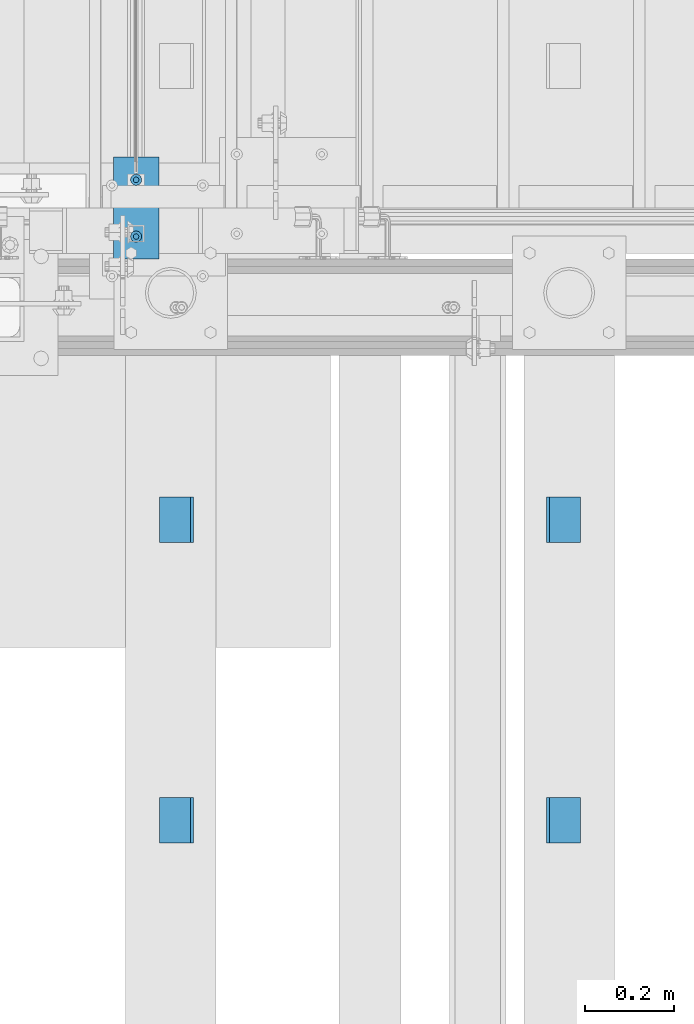
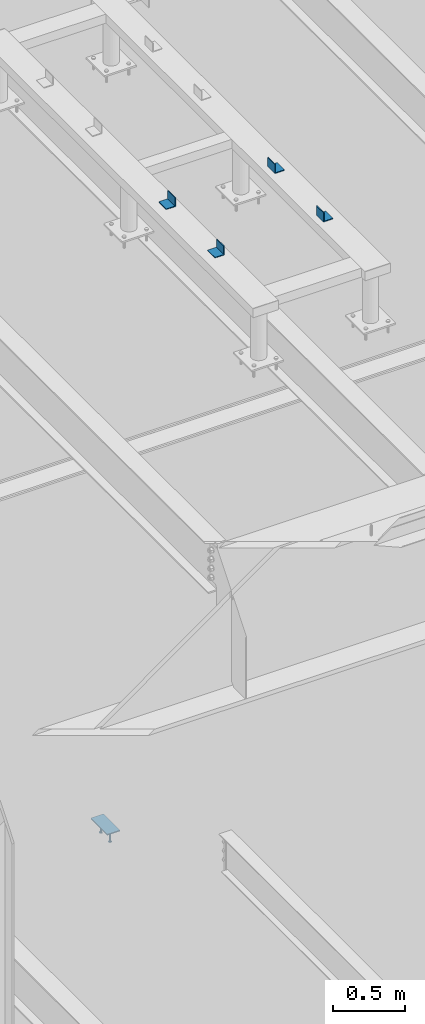
# One storey, part 901 of 1179: 7 beams, 2 elements without a shape of their own.
"""IFC2X3 building model written with IfcOpenShell, lengths in millimetres."""

from ifc_helpers import new_model, si_unit, frame, origin_with_axes, place, context, subcontext, project, spatial, faceted_brep, material, type_object, element, aggregate, save


model = new_model("IFC2X3")

# Units and contexts
model_context = context("Model", 3, precision=1e-05, world=origin_with_axes())
body_context = subcontext(model_context, "Body", "Model", "MODEL_VIEW")
ifc_project = project(units=[si_unit("LENGTHUNIT", "METRE", prefix="MILLI"), si_unit("AREAUNIT", "SQUARE_METRE"), si_unit("VOLUMEUNIT", "CUBIC_METRE"), si_unit("MASSUNIT", "GRAM", prefix="KILO"), si_unit("TIMEUNIT", "SECOND"), si_unit("PLANEANGLEUNIT", "RADIAN"), si_unit("SOLIDANGLEUNIT", "STERADIAN"), si_unit("THERMODYNAMICTEMPERATUREUNIT", "DEGREE_CELSIUS"), si_unit("LUMINOUSINTENSITYUNIT", "LUMEN")], contexts=[model_context])

# Site, building, storey
site_placement = place(None, origin_with_axes())
site = spatial("IfcSite", under=ifc_project, at=site_placement, CompositionType="ELEMENT")
building_placement = place(site_placement, origin_with_axes())
building = spatial("IfcBuilding", under=site, at=building_placement, Name="Undefined", CompositionType="ELEMENT")
storey_placement = place(building_placement, origin_with_axes())
storey = spatial("IfcBuildingStorey", under=building, at=storey_placement, Name="Undefined", CompositionType="ELEMENT", Elevation=0.0)

# Assembly, beams
assembly_1_placement = place(storey_placement, origin_with_axes())
assembly_1 = element("IfcElementAssembly", 1, at=assembly_1_placement, inside=storey, Name="EMBED", AssemblyPlace="NOTDEFINED", PredefinedType="RIGID_FRAME")
ifc_material_1 = material(Name="STEEL/A108")
beam_type_1 = type_object("IfcBeamType", Name="STUD_1/2-DIA", PredefinedType="NOTDEFINED")
beam_1_placement = place(assembly_1_placement, frame((19605.6250006919, 38144.44999694, 8137.525), z_axis=(0.0, -1.0, 0.0), x_axis=(0.0, 0.0, -1.0)))
beam_1 = element("IfcBeam", 2, at=beam_1_placement, type_object=beam_type_1, material=ifc_material_1, Name="SHEAR STUD", ObjectType="STUD_1/2-DIA", context=body_context, shape_type="Brep", body=[
    faceted_brep([(0.0, -3.1800000667572, 5.5), (0.0, -5.5, 3.1800000667572), (94.4880000000003, -5.5, 3.1800000667572), (94.4880000000003, -3.1800000667572, 5.5), (0.0, -6.34999999999854, 0.0), (94.4880000000003, -6.34999990463257, 0.0), (0.0, -5.5, -3.1800000667572), (94.4880000000003, -5.5, -3.1800000667572), (0.0, -3.1800000667572, -5.5), (94.4880000000003, -3.1800000667572, -5.5), (0.0, 0.0, -6.34999999999991), (94.4880000000003, 0.0, -6.34999990463257), (0.0, 3.1800000667572, -5.5), (94.4880000000003, 3.1800000667572, -5.5), (0.0, 5.5, -3.1800000667572), (94.4880000000003, 5.5, -3.1800000667572), (0.0, 6.34999999999854, 0.0), (94.4880000000003, 6.34999990463257, 0.0), (0.0, 5.5, 3.1800000667572), (94.4880000000003, 5.5, 3.1800000667572), (0.0, 3.1800000667572, 5.5), (94.4880000000003, 3.1800000667572, 5.5), (0.0, 0.0, 6.34999999999991), (94.4880000000003, 0.0, 6.34999990463257), (96.5200000000004, -10.9899997711182, 6.34999990463257), (96.5200000000004, -6.34000015258789, 10.9899997711182), (96.5200000000004, -12.6999998092651, 0.0), (96.5200000000004, -10.9899997711182, -6.34999990463257), (96.5200000000004, -6.34000015258789, -10.9899997711182), (96.5200000000004, 0.0, -12.6899995803833), (96.5200000000004, 6.34000015258789, -10.9899997711182), (96.5200000000004, 10.9899997711182, -6.34999990463257), (96.5200000000004, 12.6999998092651, 0.0), (96.5200000000004, 10.9899997711182, 6.34999990463257), (96.5200000000004, 6.34000015258789, 10.9899997711182), (96.5200000000004, 0.0, 12.6899995803833), (101.6, -10.9899997711182, 6.34999990463257), (101.6, -6.34000015258789, 10.9899997711182), (101.6, -12.6999998092651, 0.0), (101.6, -10.9899997711182, -6.34999990463257), (101.6, -6.34000015258789, -10.9899997711182), (101.6, 0.0, -12.6899995803833), (101.6, 6.34000015258789, -10.9899997711182), (101.6, 10.9899997711182, -6.34999990463257), (101.6, 12.6999998092651, 0.0), (101.6, 10.9899997711182, 6.34999990463257), (101.6, 6.34000015258789, 10.9899997711182), (101.6, 0.0, 12.6899995803833)], [[[0, 1, 2, 3]], [[1, 4, 5, 2]], [[4, 6, 7, 5]], [[6, 8, 9, 7]], [[8, 10, 11, 9]], [[10, 12, 13, 11]], [[12, 14, 15, 13]], [[14, 16, 17, 15]], [[16, 18, 19, 17]], [[18, 20, 21, 19]], [[20, 22, 23, 21]], [[22, 0, 3, 23]], [[22, 20, 18, 16, 14, 12, 10, 8, 6, 4, 1, 0]], [[3, 2, 24, 25]], [[2, 5, 26, 24]], [[5, 7, 27, 26]], [[7, 9, 28, 27]], [[9, 11, 29, 28]], [[11, 13, 30, 29]], [[13, 15, 31, 30]], [[15, 17, 32, 31]], [[17, 19, 33, 32]], [[19, 21, 34, 33]], [[21, 23, 35, 34]], [[23, 3, 25, 35]], [[25, 24, 36, 37]], [[24, 26, 38, 36]], [[26, 27, 39, 38]], [[27, 28, 40, 39]], [[28, 29, 41, 40]], [[29, 30, 42, 41]], [[30, 31, 43, 42]], [[31, 32, 44, 43]], [[32, 33, 45, 44]], [[33, 34, 46, 45]], [[34, 35, 47, 46]], [[35, 25, 37, 47]], [[38, 39, 40, 41, 42, 43, 44, 45, 46, 47, 37, 36]]]),
])
beam_2_placement = place(assembly_1_placement, frame((19605.6250006919, 38271.44999694, 8137.525), z_axis=(0.0, -1.0, 0.0), x_axis=(0.0, 0.0, -1.0)))
beam_2 = element("IfcBeam", 3, at=beam_2_placement, type_object=beam_type_1, material=ifc_material_1, Name="SHEAR STUD", ObjectType="STUD_1/2-DIA", context=body_context, shape_type="Brep", body=[
    faceted_brep([(0.0, -3.1800000667572, 5.5), (0.0, -5.5, 3.1800000667572), (94.4880000000003, -5.5, 3.1800000667572), (94.4880000000003, -3.1800000667572, 5.5), (0.0, -6.34999999999854, 0.0), (94.4880000000003, -6.34999990463257, 0.0), (0.0, -5.5, -3.1800000667572), (94.4880000000003, -5.5, -3.1800000667572), (0.0, -3.1800000667572, -5.5), (94.4880000000003, -3.1800000667572, -5.5), (0.0, 0.0, -6.34999999999991), (94.4880000000003, 0.0, -6.34999990463257), (0.0, 3.1800000667572, -5.5), (94.4880000000003, 3.1800000667572, -5.5), (0.0, 5.5, -3.1800000667572), (94.4880000000003, 5.5, -3.1800000667572), (0.0, 6.34999999999854, 0.0), (94.4880000000003, 6.34999990463257, 0.0), (0.0, 5.5, 3.1800000667572), (94.4880000000003, 5.5, 3.1800000667572), (0.0, 3.1800000667572, 5.5), (94.4880000000003, 3.1800000667572, 5.5), (0.0, 0.0, 6.34999999999991), (94.4880000000003, 0.0, 6.34999990463257), (96.5200000000004, -10.9899997711182, 6.34999990463257), (96.5200000000004, -6.34000015258789, 10.9899997711182), (96.5200000000004, -12.6999998092651, 0.0), (96.5200000000004, -10.9899997711182, -6.34999990463257), (96.5200000000004, -6.34000015258789, -10.9899997711182), (96.5200000000004, 0.0, -12.6899995803833), (96.5200000000004, 6.34000015258789, -10.9899997711182), (96.5200000000004, 10.9899997711182, -6.34999990463257), (96.5200000000004, 12.6999998092651, 0.0), (96.5200000000004, 10.9899997711182, 6.34999990463257), (96.5200000000004, 6.34000015258789, 10.9899997711182), (96.5200000000004, 0.0, 12.6899995803833), (101.6, -10.9899997711182, 6.34999990463257), (101.6, -6.34000015258789, 10.9899997711182), (101.6, -12.6999998092651, 0.0), (101.6, -10.9899997711182, -6.34999990463257), (101.6, -6.34000015258789, -10.9899997711182), (101.6, 0.0, -12.6899995803833), (101.6, 6.34000015258789, -10.9899997711182), (101.6, 10.9899997711182, -6.34999990463257), (101.6, 12.6999998092651, 0.0), (101.6, 10.9899997711182, 6.34999990463257), (101.6, 6.34000015258789, 10.9899997711182), (101.6, 0.0, 12.6899995803833)], [[[0, 1, 2, 3]], [[1, 4, 5, 2]], [[4, 6, 7, 5]], [[6, 8, 9, 7]], [[8, 10, 11, 9]], [[10, 12, 13, 11]], [[12, 14, 15, 13]], [[14, 16, 17, 15]], [[16, 18, 19, 17]], [[18, 20, 21, 19]], [[20, 22, 23, 21]], [[22, 0, 3, 23]], [[22, 20, 18, 16, 14, 12, 10, 8, 6, 4, 1, 0]], [[3, 2, 24, 25]], [[2, 5, 26, 24]], [[5, 7, 27, 26]], [[7, 9, 28, 27]], [[9, 11, 29, 28]], [[11, 13, 30, 29]], [[13, 15, 31, 30]], [[15, 17, 32, 31]], [[17, 19, 33, 32]], [[19, 21, 34, 33]], [[21, 23, 35, 34]], [[23, 3, 25, 35]], [[25, 24, 36, 37]], [[24, 26, 38, 36]], [[26, 27, 39, 38]], [[27, 28, 40, 39]], [[28, 29, 41, 40]], [[29, 30, 42, 41]], [[30, 31, 43, 42]], [[31, 32, 44, 43]], [[32, 33, 45, 44]], [[33, 34, 46, 45]], [[34, 35, 47, 46]], [[35, 25, 37, 47]], [[38, 39, 40, 41, 42, 43, 44, 45, 46, 47, 37, 36]]]),
])
ifc_material_2 = material(Name="STEEL/A36")
beam_type_2 = type_object("IfcBeamType", PredefinedType="NOTDEFINED")
beam_3_placement = place(assembly_1_placement, frame((19605.6250006919, 38322.24999694, 8142.2875), z_axis=(1.0, 0.0, 0.0), x_axis=(0.0, -1.0, 0.0)))
beam_3 = element("IfcBeam", 4, at=beam_3_placement, type_object=beam_type_2, material=ifc_material_2, Name="EMBED", context=body_context, shape_type="Brep", body=[
    faceted_brep([(0.0, 4.76249999999982, -50.7999999999993), (0.0, 4.76249999999982, 50.7999999999993), (228.599999999999, 4.76249999999982, 50.7999999999993), (228.599999999999, 4.76249999999982, -50.7999999999993), (0.0, -4.76249999999982, 50.7999999999993), (228.599999999999, -4.76249999999982, 50.7999999999993), (0.0, -4.76249999999982, -50.7999999999993), (228.599999999999, -4.76249999999982, -50.7999999999993)], [[[0, 1, 2, 3]], [[1, 4, 5, 2]], [[4, 6, 7, 5]], [[6, 0, 3, 7]], [[5, 7, 3, 2]], [[6, 4, 1, 0]]]),
])
aggregate(assembly_1, [beam_1, beam_2, beam_3])

assembly_2_placement = place(storey_placement, origin_with_axes())
assembly_2 = element("IfcElementAssembly", 5, at=assembly_2_placement, inside=storey, Name="FRAME", AssemblyPlace="NOTDEFINED", PredefinedType="RIGID_FRAME")
beam_type_3 = type_object("IfcBeamType", Name="L3X3X1/4", PredefinedType="NOTDEFINED")
beam_4_placement = place(assembly_2_placement, frame((19696.1125, 37459.5225542222, 13798.55), z_axis=(-1.0, 0.0, 0.0), x_axis=(0.0, 1.0, 0.0)))
beam_4 = element("IfcBeam", 6, at=beam_4_placement, type_object=beam_type_3, material=ifc_material_2, Name="ANGLE", ObjectType="L3X3X1/4", context=body_context, shape_type="Brep", body=[
    faceted_brep([(0.0, 38.0999999999985, -38.0999999999999), (0.0, 38.0999999999985, 38.0999999999999), (101.600000000035, 38.0999999999985, 38.099999999994), (101.599999999962, 38.0999999999985, -38.1000000000058), (0.0, 31.75, 38.1000000000004), (101.600000000035, 31.75, 38.099999999994), (0.0, 31.75, -31.75), (101.599999999969, 31.75, -31.7500000000064), (0.0, -38.0999999999985, -31.75), (101.599999999969, -38.0999999999985, -31.7500000000064), (0.0, -38.0999999999985, -38.0999999999999), (101.599999999962, -38.0999999999985, -38.1000000000058)], [[[0, 1, 2, 3]], [[1, 4, 5, 2]], [[4, 6, 7, 5]], [[6, 8, 9, 7]], [[8, 10, 11, 9]], [[10, 0, 3, 11]], [[5, 7, 9, 11, 3, 2]], [[10, 8, 6, 4, 1, 0]]]),
])
beam_5_placement = place(assembly_2_placement, frame((20562.8875, 37459.5225542222, 13798.55), z_axis=(0.0, 0.0, 1.0), x_axis=(0.0, 1.0, 0.0)))
beam_5 = element("IfcBeam", 7, at=beam_5_placement, type_object=beam_type_3, material=ifc_material_2, Name="ANGLE", ObjectType="L3X3X1/4", context=body_context, shape_type="Brep", body=[
    faceted_brep([(0.0, 38.0999999999985, -38.0999999999999), (0.0, 38.0999999999985, 38.0999999999999), (101.600000000035, 38.0999999999985, 38.099999999994), (101.599999999962, 38.0999999999985, -38.1000000000058), (0.0, 31.75, 38.1000000000004), (101.600000000035, 31.75, 38.099999999994), (0.0, 31.75, -31.75), (101.599999999969, 31.75, -31.7500000000064), (0.0, -38.0999999999985, -31.75), (101.599999999969, -38.0999999999985, -31.7500000000064), (0.0, -38.0999999999985, -38.0999999999999), (101.599999999962, -38.0999999999985, -38.1000000000058)], [[[0, 1, 2, 3]], [[1, 4, 5, 2]], [[4, 6, 7, 5]], [[6, 8, 9, 7]], [[8, 10, 11, 9]], [[10, 0, 3, 11]], [[5, 7, 9, 11, 3, 2]], [[10, 8, 6, 4, 1, 0]]]),
])
beam_6_placement = place(assembly_2_placement, frame((20562.8875, 36786.4225542222, 13798.55), z_axis=(0.0, 0.0, 1.0), x_axis=(0.0, 1.0, 0.0)))
beam_6 = element("IfcBeam", 8, at=beam_6_placement, type_object=beam_type_3, material=ifc_material_2, Name="ANGLE", ObjectType="L3X3X1/4", context=body_context, shape_type="Brep", body=[
    faceted_brep([(0.0, 38.0999999999985, -38.0999999999999), (0.0, 38.0999999999985, 38.0999999999999), (101.600000000035, 38.0999999999985, 38.099999999994), (101.599999999962, 38.0999999999985, -38.1000000000058), (0.0, 31.75, 38.1000000000004), (101.600000000035, 31.75, 38.099999999994), (0.0, 31.75, -31.75), (101.599999999969, 31.75, -31.7500000000064), (0.0, -38.0999999999985, -31.75), (101.599999999969, -38.0999999999985, -31.7500000000064), (0.0, -38.0999999999985, -38.0999999999999), (101.599999999962, -38.0999999999985, -38.1000000000058)], [[[0, 1, 2, 3]], [[1, 4, 5, 2]], [[4, 6, 7, 5]], [[6, 8, 9, 7]], [[8, 10, 11, 9]], [[10, 0, 3, 11]], [[5, 7, 9, 11, 3, 2]], [[10, 8, 6, 4, 1, 0]]]),
])
beam_7_placement = place(assembly_2_placement, frame((19696.1125, 36786.4225542222, 13798.55), z_axis=(-1.0, 0.0, 0.0), x_axis=(0.0, 1.0, 0.0)))
beam_7 = element("IfcBeam", 9, at=beam_7_placement, type_object=beam_type_3, material=ifc_material_2, Name="ANGLE", ObjectType="L3X3X1/4", context=body_context, shape_type="Brep", body=[
    faceted_brep([(0.0, 38.0999999999985, -38.0999999999999), (0.0, 38.0999999999985, 38.0999999999999), (101.600000000035, 38.0999999999985, 38.099999999994), (101.599999999962, 38.0999999999985, -38.1000000000058), (0.0, 31.75, 38.1000000000004), (101.600000000035, 31.75, 38.099999999994), (0.0, 31.75, -31.75), (101.599999999969, 31.75, -31.7500000000064), (0.0, -38.0999999999985, -31.75), (101.599999999969, -38.0999999999985, -31.7500000000064), (0.0, -38.0999999999985, -38.0999999999999), (101.599999999962, -38.0999999999985, -38.1000000000058)], [[[0, 1, 2, 3]], [[1, 4, 5, 2]], [[4, 6, 7, 5]], [[6, 8, 9, 7]], [[8, 10, 11, 9]], [[10, 0, 3, 11]], [[5, 7, 9, 11, 3, 2]], [[10, 8, 6, 4, 1, 0]]]),
])
aggregate(assembly_2, [beam_4, beam_5, beam_6, beam_7])

save(model, "model.ifc")
